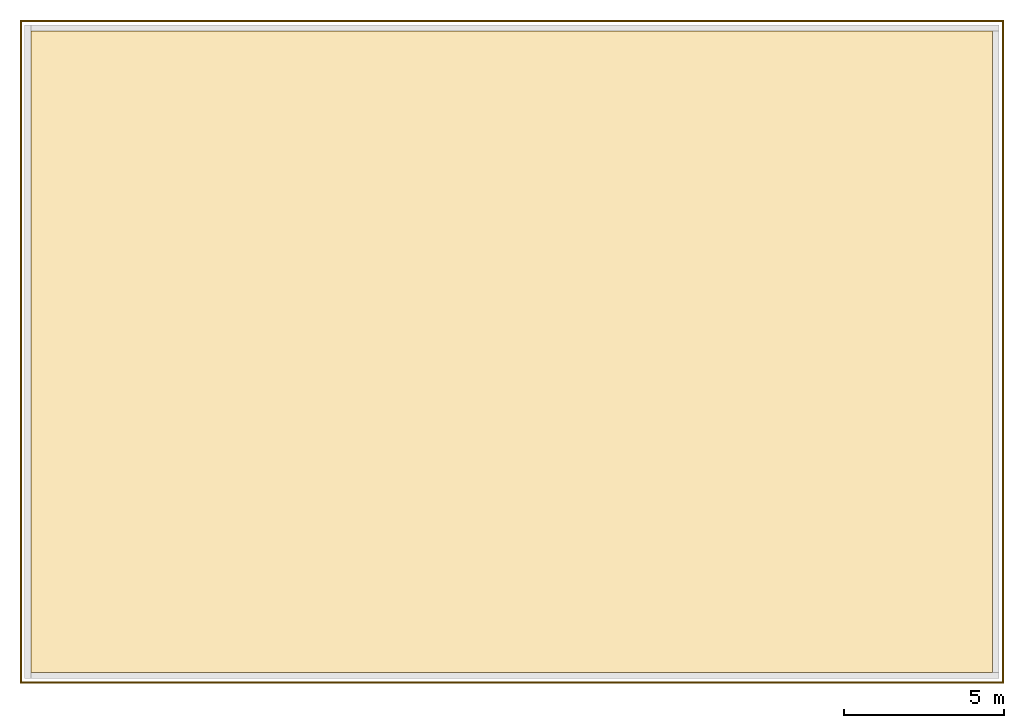
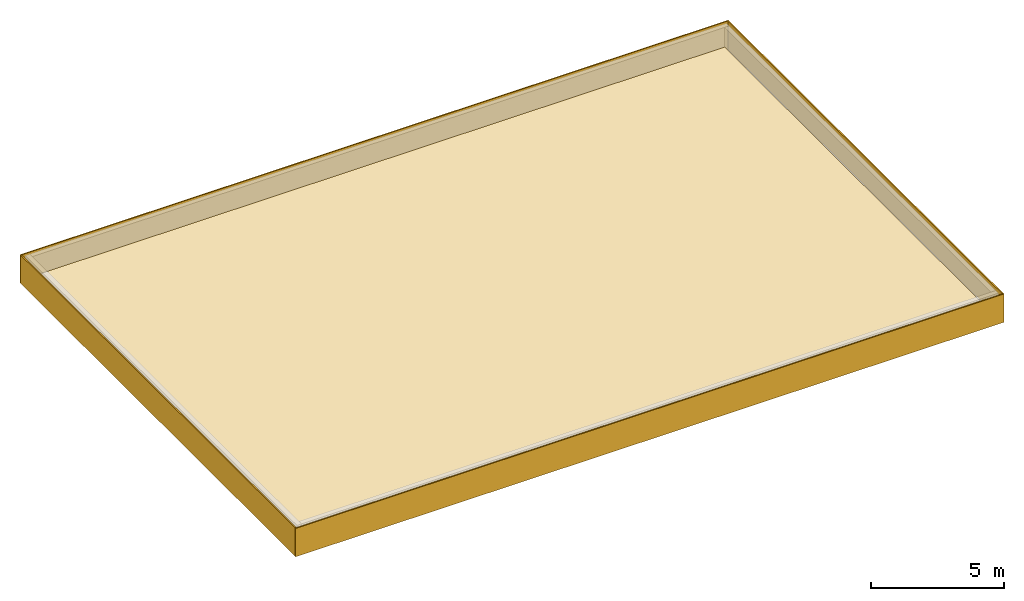
# One storey, part 2 of 2: 4 curtain walls, 1 covering.
"""IFC2X3 building model written with IfcOpenShell, lengths in metres."""

from ifc_helpers import new_model, entity, si_unit, converted_unit, frame, origin, place, context, subcontext, project, spatial, faceted_brep, material, element, save


model = new_model("IFC2X3")

# Units and contexts
model_context = context("Model", 3, precision=1e-05, world=origin())
body_context = subcontext(model_context, "Body", "Model", "MODEL_VIEW")
ifc_project = project(units=[si_unit("LENGTHUNIT", "METRE"), si_unit("AREAUNIT", "SQUARE_METRE"), si_unit("VOLUMEUNIT", "CUBIC_METRE"), si_unit("MASSUNIT", "GRAM", prefix="KILO"), converted_unit("PLANEANGLEUNIT", "DEGREE", entity("IfcPlaneAngleMeasure", 0.0174532925199433), si_unit("PLANEANGLEUNIT", "RADIAN"), dimensions=[0, 0, 0, 0, 0, 0, 0])], contexts=[model_context])

# Site, building, storey
site_placement = place(None, origin())
site = spatial("IfcSite", under=ifc_project, at=site_placement, CompositionType="ELEMENT")
building_placement = place(site_placement, origin())
building = spatial("IfcBuilding", under=site, at=building_placement, CompositionType="ELEMENT")
storey_placement = place(building_placement, frame((0.0, 0.0, 19.5)))
storey = spatial("IfcBuildingStorey", under=building, at=storey_placement, Name="Dachgeschoss", CompositionType="ELEMENT", Elevation=19.5)

# Curtain walls
ifc_material_1 = material(Name="ALU")
curtain_wall_1_placement = place(storey_placement, frame((-0.139330706017222, -0.1, 0.0)))
element("IfcCurtainWall", 1, at=curtain_wall_1_placement, inside=storey, material=ifc_material_1, Name="Profil OW standard", context=body_context, shape_type="Brep", body=[
    faceted_brep([(0.0, 0.0, 0.0), (0.0, 20.6, 0.0), (0.0, 20.6, 1.3), (0.0, 0.0, 1.3), (0.05, 20.6, 0.0), (0.05, 20.6, 1.3), (0.05, 0.0, 0.0), (0.05, 0.0, 1.3)], [[[0, 1, 2, 3]], [[1, 4, 5, 2]], [[4, 6, 7, 5]], [[6, 0, 3, 7]], [[7, 3, 2, 5]], [[0, 6, 4, 1]]], orient=[[False], [False], [False], [False], [False], [False]]),
])
ifc_material_2 = material(Name="ALU")
curtain_wall_2_placement = place(storey_placement, frame((30.5106692939828, -0.1, 0.0)))
element("IfcCurtainWall", 2, at=curtain_wall_2_placement, inside=storey, material=ifc_material_2, Name="Profil OW standard", context=body_context, shape_type="Brep", body=[
    faceted_brep([(0.0, 0.0, 0.0), (0.0, 20.6, 0.0), (0.0, 20.6, 1.3), (0.0, 0.0, 1.3), (0.05, 20.6, 0.0), (0.05, 20.6, 1.3), (0.05, 0.0, 0.0), (0.05, 0.0, 1.3)], [[[0, 1, 2, 3]], [[1, 4, 5, 2]], [[4, 6, 7, 5]], [[6, 0, 3, 7]], [[7, 3, 2, 5]], [[0, 6, 4, 1]]], orient=[[False], [False], [False], [False], [False], [False]]),
])
ifc_material_3 = material(Name="ALU")
curtain_wall_3_placement = place(storey_placement, frame((-0.139330706017223, -0.15, 0.0)))
element("IfcCurtainWall", 3, at=curtain_wall_3_placement, inside=storey, material=ifc_material_3, Name="Profil OW standard", context=body_context, shape_type="Brep", body=[
    faceted_brep([(0.0, 0.0500000000000051, 0.0), (30.7, 0.05, 0.0), (30.7, 0.05, 1.3), (0.0, 0.0500000000000051, 1.3), (30.7, 0.0, 0.0), (30.7, 0.0, 1.3), (0.0, 5.03064256918151e-15, 0.0), (0.0, 5.03064256918151e-15, 1.3)], [[[0, 1, 2, 3]], [[1, 4, 5, 2]], [[4, 6, 7, 5]], [[6, 0, 3, 7]], [[7, 3, 2, 5]], [[0, 6, 4, 1]]], orient=[[False], [False], [False], [False], [False], [False]]),
])
ifc_material_4 = material(Name="ALU")
curtain_wall_4_placement = place(storey_placement, frame((-0.139330706017223, 20.5, 0.0)))
element("IfcCurtainWall", 4, at=curtain_wall_4_placement, inside=storey, material=ifc_material_4, Name="Profil OW standard", context=body_context, shape_type="Brep", body=[
    faceted_brep([(0.0, 0.05, 0.0), (30.7, 0.0499999999999964, 0.0), (30.7, 0.0499999999999964, 1.3), (0.0, 0.05, 1.3), (30.7, -3.63797880709171e-15, 0.0), (30.7, -3.63797880709171e-15, 1.3), (0.0, 0.0, 0.0), (0.0, 0.0, 1.3)], [[[0, 1, 2, 3]], [[1, 4, 5, 2]], [[4, 6, 7, 5]], [[6, 0, 3, 7]], [[7, 3, 2, 5]], [[0, 6, 4, 1]]], orient=[[False], [False], [False], [False], [False], [False]]),
])

# Covering
ifc_material_5 = material()
covering_placement = place(storey_placement, frame((0.200000000000003, 0.2, 0.3)))
element("IfcCovering", 5, at=covering_placement, inside=storey, material=ifc_material_5, PredefinedType="NOTDEFINED", context=body_context, shape_type="Brep", body=[
    faceted_brep([(2.27373675443232e-16, 20.0, 0.1), (2.27373675443232e-16, 20.0, 0.0), (30.0, 20.0, 0.0), (30.0, 20.0, 0.1), (30.0, 2.27373675443232e-16, 0.0), (30.0, 2.27373675443232e-16, 0.1), (2.27373675443232e-16, 2.27373675443232e-16, 0.0), (2.27373675443232e-16, 2.27373675443232e-16, 0.1)], [[[0, 1, 2, 3]], [[3, 2, 4, 5]], [[5, 4, 6, 7]], [[7, 6, 1, 0]], [[0, 3, 5, 7]], [[1, 6, 4, 2]]], orient=[[False], [False], [False], [False], [False], [False]]),
])

save(model, "model.ifc")
